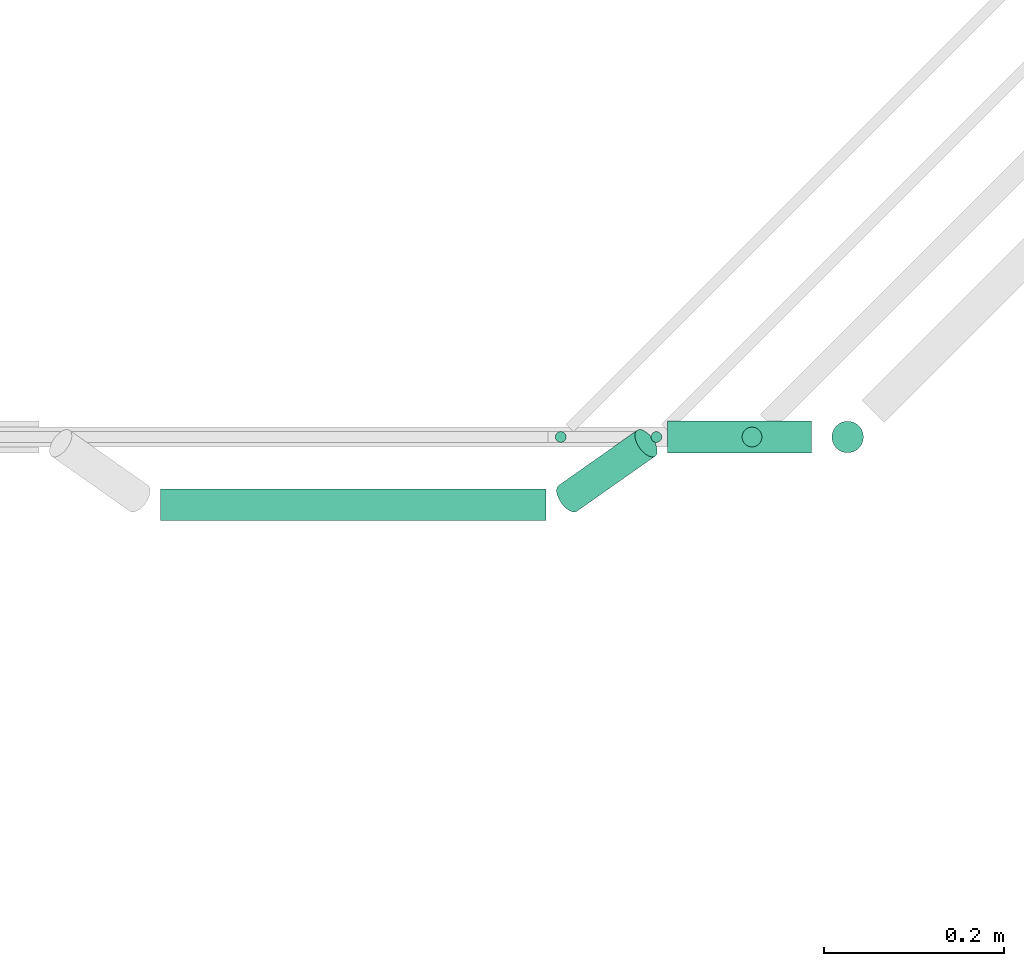
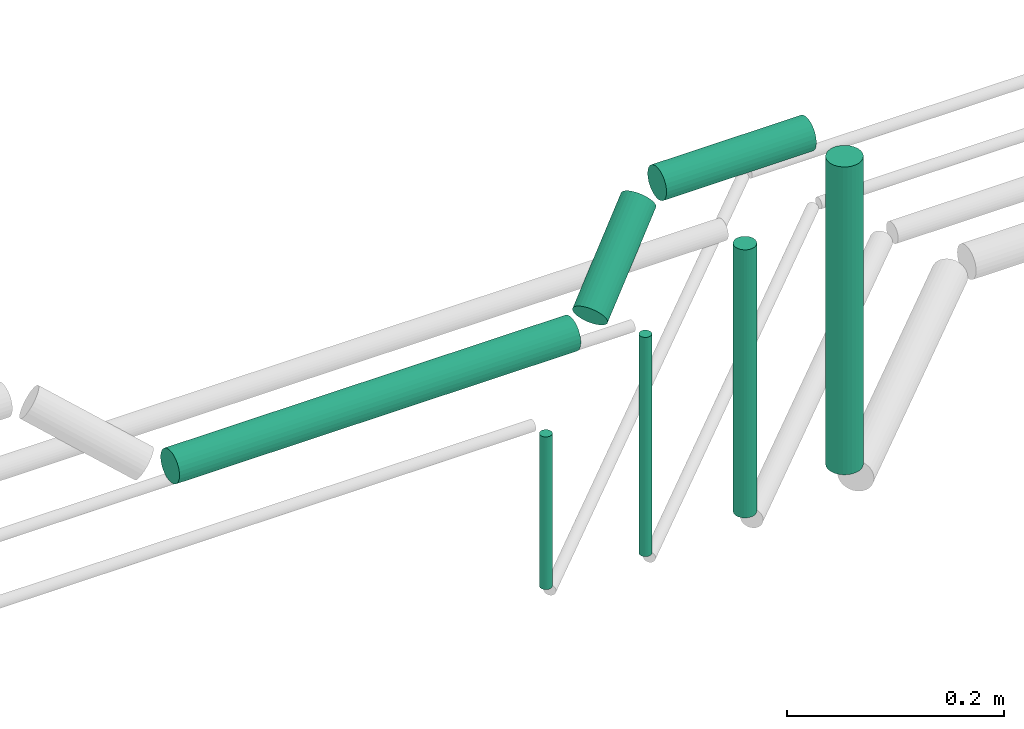
# One storey, part 182 of 331: 7 flow segments.
"""IFC2X3 building model written with IfcOpenShell, lengths in millimetres."""

from ifc_helpers import new_model, entity, si_unit, converted_unit, derived_unit, direction, frame, frame_2d, origin, origin_2d_with_axis, place, context, subcontext, project, spatial, circle, extrude, type_object, element, save


model = new_model("IFC2X3")

# Units and contexts
model_context = context("Model", 3, precision=0.01, world=origin(), true_north=direction((6.12303176911189e-17, 1.0)))
body_context = subcontext(model_context, "Body", "Model", "MODEL_VIEW")
ifc_project = project(units=[si_unit("LENGTHUNIT", "METRE", prefix="MILLI"), si_unit("AREAUNIT", "SQUARE_METRE"), si_unit("VOLUMEUNIT", "CUBIC_METRE"), converted_unit("PLANEANGLEUNIT", "DEGREE", entity("IfcRatioMeasure", 0.0174532925199433), si_unit("PLANEANGLEUNIT", "RADIAN"), dimensions=[0, 0, 0, 0, 0, 0, 0]), si_unit("MASSUNIT", "GRAM", prefix="KILO"), derived_unit("MASSDENSITYUNIT", [(si_unit("MASSUNIT", "GRAM", prefix="KILO"), 1), (si_unit("LENGTHUNIT", "METRE"), -3)]), derived_unit("MOMENTOFINERTIAUNIT", [(si_unit("LENGTHUNIT", "METRE"), 4)]), si_unit("TIMEUNIT", "SECOND"), si_unit("FREQUENCYUNIT", "HERTZ"), si_unit("THERMODYNAMICTEMPERATUREUNIT", "DEGREE_CELSIUS"), derived_unit("THERMALTRANSMITTANCEUNIT", [(si_unit("MASSUNIT", "GRAM", prefix="KILO"), 1), (si_unit("THERMODYNAMICTEMPERATUREUNIT", "KELVIN"), -1), (si_unit("TIMEUNIT", "SECOND"), -3)]), derived_unit("VOLUMETRICFLOWRATEUNIT", [(si_unit("LENGTHUNIT", "METRE"), 3), (si_unit("TIMEUNIT", "SECOND"), -1)]), derived_unit("MASSFLOWRATEUNIT", [(si_unit("MASSUNIT", "GRAM", prefix="KILO"), 1), (si_unit("TIMEUNIT", "SECOND"), -1)]), derived_unit("ROTATIONALFREQUENCYUNIT", [(si_unit("TIMEUNIT", "SECOND"), -1)]), si_unit("ELECTRICCURRENTUNIT", "AMPERE"), si_unit("ELECTRICVOLTAGEUNIT", "VOLT"), si_unit("POWERUNIT", "WATT"), si_unit("FORCEUNIT", "NEWTON", prefix="KILO"), si_unit("ILLUMINANCEUNIT", "LUX"), si_unit("LUMINOUSFLUXUNIT", "LUMEN"), si_unit("LUMINOUSINTENSITYUNIT", "CANDELA"), derived_unit("USERDEFINED", [(si_unit("MASSUNIT", "GRAM", prefix="KILO"), -1), (si_unit("LENGTHUNIT", "METRE"), -2), (si_unit("TIMEUNIT", "SECOND"), 3), (si_unit("LUMINOUSFLUXUNIT", "LUMEN"), 1)]), derived_unit("LINEARVELOCITYUNIT", [(si_unit("LENGTHUNIT", "METRE"), 1), (si_unit("TIMEUNIT", "SECOND"), -1)]), si_unit("PRESSUREUNIT", "PASCAL"), derived_unit("USERDEFINED", [(si_unit("LENGTHUNIT", "METRE"), -2), (si_unit("MASSUNIT", "GRAM", prefix="KILO"), 1), (si_unit("TIMEUNIT", "SECOND"), -2)]), derived_unit("LINEARFORCEUNIT", [(si_unit("MASSUNIT", "GRAM", prefix="KILO"), 1), (si_unit("LENGTHUNIT", "METRE"), 1), (si_unit("TIMEUNIT", "SECOND"), -2), (si_unit("LENGTHUNIT", "METRE"), -1)]), derived_unit("PLANARFORCEUNIT", [(si_unit("MASSUNIT", "GRAM", prefix="KILO"), 1), (si_unit("LENGTHUNIT", "METRE"), 1), (si_unit("TIMEUNIT", "SECOND"), -2), (si_unit("LENGTHUNIT", "METRE"), -2)])], contexts=[model_context])

# Site, building, storey
site_placement = place(None, frame((0.0, -0.00077364408347762, 0.0)))
site = spatial("IfcSite", under=ifc_project, at=site_placement, CompositionType="ELEMENT")
building_placement = place(site_placement, origin())
building = spatial("IfcBuilding", under=site, at=building_placement, CompositionType="ELEMENT")
storey_placement = place(building_placement, origin())
storey = spatial("IfcBuildingStorey", under=building, at=storey_placement, CompositionType="ELEMENT", Elevation=0.0)

# Flow segments
pipe_segment_type = type_object("IfcPipeSegmentType", PredefinedType="NOTDEFINED")
flow_segment_1_placement = place(storey_placement, frame((41376.2790356757, 9255.86950777334, 18780.8686623365)))
element("IfcFlowSegment", 1, at=flow_segment_1_placement, inside=storey, type_object=pipe_segment_type, context=body_context, shape_type="SweptSolid", body=[
    extrude(circle(Radius=17.5, at=frame_2d((1.39163339068159e-15, -2.16430919033906e-12), x_axis=(1.0, 0.0))), frame((0.00402340936511791, 19.0952720101136, 19.0952719991387), z_axis=(0.999999973567184, 0.000160642212488555, 0.000164498364512932), x_axis=(0.000160642214662021, -0.999999987097039, 0.0)), (0.0, 0.0, 1.0), 427.736189243355),
])
flow_segment_2_placement = place(storey_placement, frame((41812.5038280613, 9342.40472776411, 18464.0)))
element("IfcFlowSegment", 2, at=flow_segment_2_placement, inside=storey, type_object=pipe_segment_type, context=body_context, shape_type="SweptSolid", body=[
    extrude(circle(Radius=6.0, at=origin_2d_with_axis()), frame((7.59527223591454, 7.59527223591562, 0.0), z_axis=(0.0, 0.0, 1.0), x_axis=(-1.0, 0.0, 0.0)), (0.0, 0.0, 1.0), 172.000000003255),
])
flow_segment_3_placement = place(building_placement, frame((41918.5698452391, 9342.40472776402, 18464.0)))
element("IfcFlowSegment", 3, at=flow_segment_3_placement, inside=storey, type_object=pipe_segment_type, context=body_context, shape_type="SweptSolid", body=[
    extrude(circle(Radius=6.0, at=frame_2d((0.0, -1.08286712929839e-12), x_axis=(1.0, 0.0))), frame((7.59527223591454, 7.59527223591454, 0.0), z_axis=(0.0, 0.0, 1.0), x_axis=(-1.0, 0.0, 0.0)), (0.0, 0.0, 1.0), 247.000000005664),
])
flow_segment_4_placement = place(building_placement, frame((42019.6358624171, 9337.40472776402, 18474.0)))
element("IfcFlowSegment", 4, at=flow_segment_4_placement, inside=storey, type_object=pipe_segment_type, context=body_context, shape_type="SweptSolid", body=[
    extrude(circle(Radius=11.0, at=origin_2d_with_axis()), frame((12.5952722359134, 12.5952722359156, 0.0), z_axis=(0.0, 0.0, 1.0), x_axis=(-1.0, 0.0, 0.0)), (0.0, 0.0, 1.0), 301.999999996254),
])
flow_segment_5_placement = place(storey_placement, frame((41813.9394922531, 9265.23068219403, 18790.4689325085)))
element("IfcFlowSegment", 5, at=flow_segment_5_placement, inside=storey, type_object=pipe_segment_type, context=body_context, shape_type="SweptSolid", body=[
    extrude(circle(Radius=17.5, at=frame_2d((-8.8574356595739e-13, 3.16182943010161e-13), x_axis=(1.0, 0.0))), frame((13.9464959044825, 16.7443544616293, 16.6735371098501), z_axis=(0.704767964681786, 0.495663956673462, 0.507562171574184), x_axis=(0.575273037999294, -0.817961448817158, 0.0)), (0.0, 0.0, 1.0), 123.240084595374),
])
flow_segment_6_placement = place(building_placement, frame((41938.6084032506, 9330.90472776448, 18857.7050727467)))
element("IfcFlowSegment", 6, at=flow_segment_6_placement, inside=storey, type_object=pipe_segment_type, context=body_context, shape_type="SweptSolid", body=[
    extrude(circle(Radius=17.5, at=frame_2d((1.08286712929839e-12, 0.0), x_axis=(1.0, 0.0))), frame((0.0, 19.0952722359173, 19.0952722359163), z_axis=(1.0, 0.0, 0.0), x_axis=(0.0, 1.0, 0.0)), (0.0, 0.0, 1.0), 159.688748580852),
])
flow_segment_7_placement = place(building_placement, frame((42119.2018795956, 9330.90472776448, 18490.0)))
element("IfcFlowSegment", 7, at=flow_segment_7_placement, inside=storey, type_object=pipe_segment_type, context=body_context, shape_type="SweptSolid", body=[
    extrude(circle(Radius=17.5, at=origin_2d_with_axis()), frame((19.0952722359119, 19.0952722359163, 0.0), z_axis=(0.0, 0.0, 1.0), x_axis=(-1.0, 0.0, 0.0)), (0.0, 0.0, 1.0), 346.800344982625),
])

save(model, "model.ifc")
